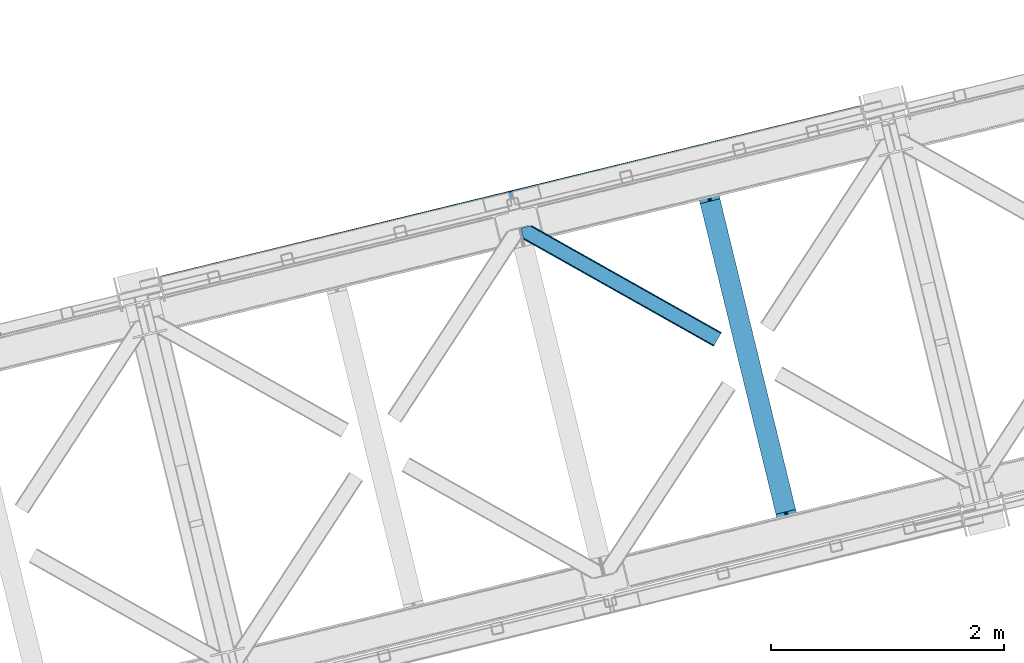
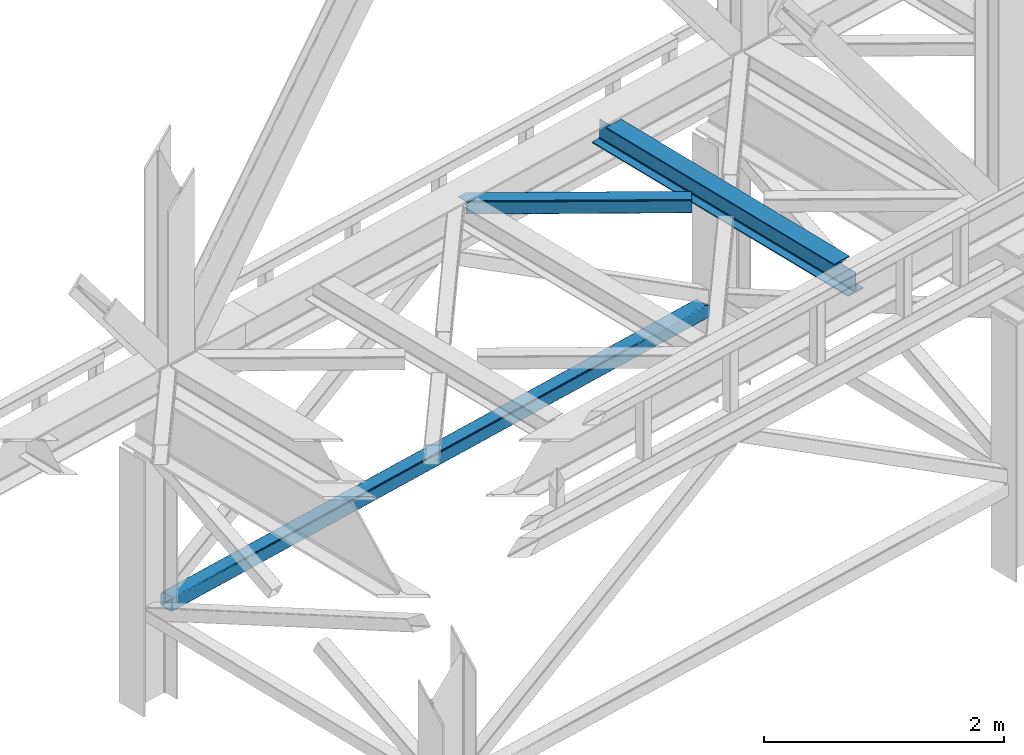
# One storey, part 48 of 93: 2 members, 1 beam.
"""IFC4 building model written with IfcOpenShell, lengths in millimetres."""

import ifcopenshell
import ifcopenshell.guid

model = None  # the IFC model being written
_history = None  # IfcOwnerHistory: only IFC2X3 demands one
_inside = {}  # id of a spatial element -> (the spatial element, [elements in it])
_under = {}  # id of a project, library or spatial element -> (it, [spatial elements below it])
_declared = {}  # id of a project -> (the project, [libraries it declares])
_typed = {}  # id of a type object -> (the type object, [elements of that type])
_made_of = {}  # id of a material, layer set ... -> (it, [elements and type objects made of it])


def new_model(schema):
    """Start an empty IFC model of exactly this schema.

    Asked for "IFC4X3", IfcOpenShell would pick the latest addendum, in which some entities
    have other attributes; the version numbers below select the first issue.
    IFC2X3 requires an IfcOwnerHistory on every rooted entity: one is made here for all.
    """
    global model, _history
    if schema == "IFC4X3":
        model = ifcopenshell.file(schema_version=(4, 3, 0, 0))
    else:
        model = ifcopenshell.file(schema=schema)
    _inside.clear()
    _under.clear()
    _declared.clear()
    _typed.clear()
    _made_of.clear()
    _history = None
    if model.schema == "IFC2X3":
        org = make("IfcOrganization", Name="unknown")
        user = make(
            "IfcPersonAndOrganization",
            ThePerson=make("IfcPerson", FamilyName="unknown"),
            TheOrganization=org,
        )
        app = make(
            "IfcApplication",
            ApplicationDeveloper=org,
            Version="unknown",
            ApplicationFullName="unknown",
            ApplicationIdentifier="unknown",
        )
        _history = make(
            "IfcOwnerHistory",
            OwningUser=user,
            OwningApplication=app,
            ChangeAction="ADDED",
            CreationDate=0,
        )
    return model


def make(cls, **values):
    """One entity of the class cls with the attributes given. An attribute that is None is left unset."""
    return model.create_entity(
        cls, **{name: value for name, value in values.items() if value is not None}
    )


def entity(cls, *values):
    """Any entity or typed value of the class cls, its attributes in the order of the schema. None: left unset."""
    e = model.create_entity(cls)
    for i, value in enumerate(values):
        if value is not None:
            e[i] = value
    return e


def rooted(cls, **values):
    """An entity with a GlobalId (a new one), such as an element, a storey or a relation."""
    return make(cls, GlobalId=ifcopenshell.guid.new(), OwnerHistory=_history, **values)


def si_unit(unit_type, name, prefix=None):
    """IfcSIUnit, for example si_unit("LENGTHUNIT", "METRE", prefix="MILLI")."""
    return make("IfcSIUnit", UnitType=unit_type, Prefix=prefix, Name=name)


def converted_unit(unit_type, name, factor, base, dimensions=None, offset=None):
    """IfcConversionBasedUnit, such as the inch: factor (a typed value) times the base unit."""
    return make(
        "IfcConversionBasedUnit"
        if offset is None
        else "IfcConversionBasedUnitWithOffset",
        ConversionOffset=offset,
        Dimensions=None
        if dimensions is None
        else entity("IfcDimensionalExponents", *dimensions),
        UnitType=unit_type,
        Name=name,
        ConversionFactor=make(
            "IfcMeasureWithUnit", ValueComponent=factor, UnitComponent=base
        ),
    )


def derived_unit(unit_type, elements):
    """IfcDerivedUnit: a product of units, each with its exponent."""
    return make(
        "IfcDerivedUnit",
        Elements=[
            make("IfcDerivedUnitElement", Unit=unit, Exponent=power)
            for unit, power in elements
        ],
        UnitType=unit_type,
    )


def assignment(units):
    """IfcUnitAssignment: the units of a project."""
    return None if units is None else make("IfcUnitAssignment", Units=units)


def point(xyz):
    """IfcCartesianPoint."""
    return None if xyz is None else make("IfcCartesianPoint", Coordinates=xyz)


def direction(xyz):
    """IfcDirection."""
    return None if xyz is None else make("IfcDirection", DirectionRatios=xyz)


def frame(location, z_axis=None, x_axis=None):
    """IfcAxis2Placement3D, a coordinate frame: its origin and axes. An axis left out is left unset."""
    return make(
        "IfcAxis2Placement3D",
        Location=point(location),
        Axis=direction(z_axis),
        RefDirection=direction(x_axis),
    )


def origin():
    """The frame at (0, 0, 0) with its axes left unset."""
    return frame((0.0, 0.0, 0.0))


def place(relative_to, where):
    """IfcLocalPlacement: puts the frame where relative to a parent placement (None: the world)."""
    return make(
        "IfcLocalPlacement", PlacementRelTo=relative_to, RelativePlacement=where
    )


def context(
    kind, dimensions, precision=None, world=None, true_north=None, identifier=None
):
    """IfcGeometricRepresentationContext, for example the 3D "Model" context."""
    return make(
        "IfcGeometricRepresentationContext",
        ContextIdentifier=identifier,
        ContextType=kind,
        CoordinateSpaceDimension=dimensions,
        Precision=precision,
        WorldCoordinateSystem=world,
        TrueNorth=true_north,
    )


def subcontext(parent, identifier, kind, view, scale=None):
    """IfcGeometricRepresentationSubContext, for example "Body" below "Model"."""
    return make(
        "IfcGeometricRepresentationSubContext",
        ContextIdentifier=identifier,
        ContextType=kind,
        ParentContext=parent,
        TargetScale=scale,
        TargetView=view,
    )


def project(units=None, contexts=None):
    """IfcProject with its units and contexts."""
    return rooted(
        "IfcProject",
        Name="project",
        RepresentationContexts=contexts,
        UnitsInContext=assignment(units),
    )


def spatial(cls, under=None, at=None, **own):
    """A site, building, storey or space (cls), placed at a placement, below another one or the project."""
    s = rooted(cls, ObjectPlacement=at, **own)
    if under is not None:
        _under.setdefault(under.id(), (under, []))[1].append(s)
    return s


def point_list(points):
    """IfcCartesianPointList2D or 3D."""
    cls = (
        "IfcCartesianPointList2D" if len(points[0]) == 2 else "IfcCartesianPointList3D"
    )
    return make(cls, CoordList=points)


def triangles(points, corners, closed=None, point_numbers=None):
    """IfcTriangulatedFaceSet: each triangle names its three corners, points numbered from 1."""
    return make(
        "IfcTriangulatedFaceSet",
        Coordinates=point_list(points),
        Closed=closed,
        CoordIndex=corners,
        PnIndex=point_numbers,
    )


def polygons(points, faces, closed=None, point_numbers=None):
    """IfcPolygonalFaceSet: a face is its outer loop, then its inner loops; points numbered from 1."""
    made = []
    for loops in faces:
        if len(loops) == 1:
            made.append(make("IfcIndexedPolygonalFace", CoordIndex=loops[0]))
        else:
            made.append(
                make(
                    "IfcIndexedPolygonalFaceWithVoids",
                    CoordIndex=loops[0],
                    InnerCoordIndices=loops[1:],
                )
            )
    return make(
        "IfcPolygonalFaceSet",
        Coordinates=point_list(points),
        Closed=closed,
        Faces=made,
        PnIndex=point_numbers,
    )


def shape(context_of_items, identifier, shape_type, items):
    """IfcShapeRepresentation: the items that make up one representation, for example the "Body"."""
    return make(
        "IfcShapeRepresentation",
        ContextOfItems=context_of_items,
        RepresentationIdentifier=identifier,
        RepresentationType=shape_type,
        Items=items,
    )


def material(Name=None, Category=None):
    """IfcMaterial."""
    return make("IfcMaterial", Name=Name, Category=Category)


def made_of(thing, what):
    """Note that an element or type object is made of a material, layer set ...; save() writes the relation."""
    if what is not None:
        _made_of.setdefault(what.id(), (what, []))[1].append(thing)
    return thing


def type_object(cls, material=None, **own):
    """A type object (cls), such as IfcWallType, which elements share."""
    return made_of(rooted(cls, **own), material)


def element(
    cls,
    number,
    at=None,
    inside=None,
    cuts=None,
    type_object=None,
    material=None,
    context=None,
    identifier="Body",
    shape_type=None,
    held_by="IfcProductDefinitionShape",
    body=None,
    shapes=None,
    **own,
):
    """One element of the class cls, such as IfcWall. Its Tag is "e" and its number.

    at: its placement. inside: the storey or other place that contains it. cuts: it is an
    opening in that element (IfcRelVoidsElement). A single representation is given by context,
    identifier, shape_type and body (its items); several are given by shapes. held_by: the class
    of the entity that holds the representations. save() writes the other relations.
    """
    e = rooted(cls, Tag="e%d" % number, ObjectPlacement=at, **own)
    if body is not None:
        shapes = [shape(context, identifier, shape_type, body)]
    if shapes is not None:
        e.Representation = make(held_by, Representations=shapes)
    if inside is not None:
        _inside.setdefault(inside.id(), (inside, []))[1].append(e)
    if cuts is not None:
        rooted(
            "IfcRelVoidsElement", RelatingBuildingElement=cuts, RelatedOpeningElement=e
        )
    if type_object is not None:
        _typed.setdefault(type_object.id(), (type_object, []))[1].append(e)
    return made_of(e, material)


def aggregate(whole, parts):
    """IfcRelAggregates: a whole, such as a stair, and the parts it consists of."""
    return rooted("IfcRelAggregates", RelatingObject=whole, RelatedObjects=parts)


def save(model, path):
    """Write the relations noted so far, then the file.

    IfcRelAggregates (storeys below a building ...), IfcRelContainedInSpatialStructure (elements
    in a storey), IfcRelDefinesByType, IfcRelAssociatesMaterial and IfcRelDeclares: one each for
    every whole, place, type object, material and project.
    """
    for whole, parts in _under.values():
        aggregate(whole, parts)
    for where, things in _inside.values():
        rooted(
            "IfcRelContainedInSpatialStructure",
            RelatedElements=things,
            RelatingStructure=where,
        )
    for kind, things in _typed.values():
        rooted("IfcRelDefinesByType", RelatedObjects=things, RelatingType=kind)
    for what, things in _made_of.values():
        rooted("IfcRelAssociatesMaterial", RelatedObjects=things, RelatingMaterial=what)
    for by, libraries in _declared.values():
        rooted("IfcRelDeclares", RelatingContext=by, RelatedDefinitions=libraries)
    model.write(path)


model = new_model("IFC4")

# Units and contexts
model_context = context("Model", 3, precision=0.01, world=origin(), true_north=direction((6.12303176911189e-17, 1.0)))
plan_context = context("Plan", 3, precision=0.01, world=origin(), true_north=direction((6.12303176911189e-17, 1.0)))
body_context = subcontext(model_context, "Body", "Model", "MODEL_VIEW")
ifc_project = project(units=[si_unit("LENGTHUNIT", "METRE", prefix="MILLI"), si_unit("AREAUNIT", "SQUARE_METRE"), si_unit("VOLUMEUNIT", "CUBIC_METRE"), converted_unit("PLANEANGLEUNIT", "DEGREE", entity("IfcRatioMeasure", 0.0174532925199433), si_unit("PLANEANGLEUNIT", "RADIAN"), dimensions=[0, 0, 0, 0, 0, 0, 0]), si_unit("MASSUNIT", "GRAM", prefix="KILO"), derived_unit("MASSDENSITYUNIT", [(si_unit("MASSUNIT", "GRAM", prefix="KILO"), 1), (si_unit("LENGTHUNIT", "METRE"), -3)]), derived_unit("MOMENTOFINERTIAUNIT", [(si_unit("LENGTHUNIT", "METRE"), 4)]), si_unit("TIMEUNIT", "SECOND"), si_unit("FREQUENCYUNIT", "HERTZ"), si_unit("THERMODYNAMICTEMPERATUREUNIT", "DEGREE_CELSIUS"), derived_unit("THERMALTRANSMITTANCEUNIT", [(si_unit("MASSUNIT", "GRAM", prefix="KILO"), 1), (si_unit("THERMODYNAMICTEMPERATUREUNIT", "KELVIN"), -1), (si_unit("TIMEUNIT", "SECOND"), -3)]), derived_unit("VOLUMETRICFLOWRATEUNIT", [(si_unit("LENGTHUNIT", "METRE"), 3), (si_unit("TIMEUNIT", "SECOND"), -1)]), derived_unit("MASSFLOWRATEUNIT", [(si_unit("MASSUNIT", "GRAM", prefix="KILO"), 1), (si_unit("TIMEUNIT", "SECOND"), -1)]), derived_unit("ROTATIONALFREQUENCYUNIT", [(si_unit("TIMEUNIT", "SECOND"), -1)]), si_unit("ELECTRICCURRENTUNIT", "AMPERE"), si_unit("ELECTRICVOLTAGEUNIT", "VOLT"), si_unit("POWERUNIT", "WATT"), si_unit("FORCEUNIT", "NEWTON", prefix="KILO"), si_unit("ILLUMINANCEUNIT", "LUX"), si_unit("LUMINOUSFLUXUNIT", "LUMEN"), si_unit("LUMINOUSINTENSITYUNIT", "CANDELA"), derived_unit("USERDEFINED", [(si_unit("MASSUNIT", "GRAM", prefix="KILO"), -1), (si_unit("LENGTHUNIT", "METRE"), -2), (si_unit("TIMEUNIT", "SECOND"), 3), (si_unit("LUMINOUSFLUXUNIT", "LUMEN"), 1)]), derived_unit("LINEARVELOCITYUNIT", [(si_unit("LENGTHUNIT", "METRE"), 1), (si_unit("TIMEUNIT", "SECOND"), -1)]), si_unit("PRESSUREUNIT", "PASCAL"), derived_unit("USERDEFINED", [(si_unit("LENGTHUNIT", "METRE"), -2), (si_unit("MASSUNIT", "GRAM", prefix="KILO"), 1), (si_unit("TIMEUNIT", "SECOND"), -2)]), derived_unit("LINEARFORCEUNIT", [(si_unit("MASSUNIT", "GRAM", prefix="KILO"), 1), (si_unit("LENGTHUNIT", "METRE"), 1), (si_unit("TIMEUNIT", "SECOND"), -2), (si_unit("LENGTHUNIT", "METRE"), -1)]), derived_unit("PLANARFORCEUNIT", [(si_unit("MASSUNIT", "GRAM", prefix="KILO"), 1), (si_unit("LENGTHUNIT", "METRE"), 1), (si_unit("TIMEUNIT", "SECOND"), -2), (si_unit("LENGTHUNIT", "METRE"), -2)])], contexts=[model_context, plan_context])

# Site, building, storey
site_placement = place(None, origin())
site = spatial("IfcSite", under=ifc_project, at=site_placement, CompositionType="ELEMENT")
building_placement = place(site_placement, origin())
building = spatial("IfcBuilding", under=site, at=building_placement, CompositionType="ELEMENT")
storey_placement = place(building_placement, frame((0.0, 0.0, 15900.0)))
storey = spatial("IfcBuildingStorey", under=building, at=storey_placement, CompositionType="ELEMENT", Elevation=15900.0)

# Beam
ifc_material = material(Name="Metal painted (White)")
beam_type = type_object("IfcBeamType", PredefinedType="BEAM")
beam_placement = place(storey_placement, frame((-38213.1659577761, 8471.84131437829, 3441.0)))
element("IfcBeam", 1, at=beam_placement, inside=storey, type_object=beam_type, material=ifc_material, ObjectType="Steel Beam", PredefinedType="BEAM", context=body_context, shape_type="Tessellation", body=[
    polygons([(900.985346189436, 41.4445662733092, 11.000000000004), (900.985346189436, 41.4445662733092, 2.16573425859679e-12), (170.021610174757, 3040.13999372697, 2.16573425859679e-12), (170.021610174765, 3040.13999372697, 11.000000000004), (834.91980623581, 25.3403919499667, 11.000000000004), (103.956070221139, 3024.03581940363, 11.000000000004), (828.971056214518, 23.8903211957407, 12.2179274798217), (98.007320199847, 3022.5857486494, 12.2179274798217), (823.927949458409, 22.6610105689183, 15.6862915010235), (92.9642134437384, 3021.35643802258, 15.6862915010235), (820.558253255242, 21.8396114687119, 20.8770650821657), (89.5945172405625, 3020.53503892237, 20.8770650821657), (819.374973305547, 21.5511744621206, 27.0000000000047), (88.4112372908679, 3020.24660191578, 27.0000000000047), (81.6103728838801, 3018.58881926485, 27.0000000000047), (81.6103728838801, 3018.58881926485, 203.000000000006), (88.4112372908766, 3020.24660191578, 203.000000000006), (4.33146851719357e-12, 2998.69542745366, 2.16573425859679e-12), (4.33146851719357e-12, 2998.69542745366, 10.9999999999997), (66.0655399536129, 3014.799601777, 11.000000000004), (72.0142899749097, 3016.24967253123, 12.2179274798217), (77.0573967310183, 3017.47898315805, 15.6862915010192), (80.4270929341986, 3018.30038225826, 20.8770650821657), (819.374973305556, 21.5511744621206, 203.000000000006), (812.574108898559, 19.8933918111876, 203.000000000006), (812.574108898559, 19.8933918111876, 27.0000000000047), (811.390828948878, 19.6049548045963, 20.8770650821657), (808.021132745698, 18.7835557043887, 15.6862915010192), (802.978025989589, 17.5542450775685, 12.2179274798217), (797.029275968292, 16.1041743233403, 11.000000000004), (730.963736014684, 0.0, 10.9999999999997), (730.963736014684, 0.0, 2.16573425859679e-12), (779.675212882762, 184.415062601692, 203.069791966819), (128.020401343508, 2857.75452019162, 203.000000000006), (128.243282132658, 2856.8401777572, 203.617301946336), (128.256196377182, 2856.7871977843, 217.000003693143), (779.530009633833, 185.010597404073, 217.000003676718), (779.530880241726, 185.007025963194, 204.00000679514), (772.964911718315, 182.385463974441, 203.006342981529), (772.742064056778, 183.299815969775, 203.617301946336), (772.72914981225, 183.352795942668, 217.000003693143), (121.455336555608, 2855.1293963229, 217.000003676718), (121.45446594771, 2855.13296776377, 204.00000679514), (121.31016635866, 2855.72494066435, 203.076120467494), (121.21953693652, 2856.09673754069, 203.000000000006), (780.713494357868, 185.298194377514, 223.122939328039), (784.082490766535, 186.122464201392, 228.313710402595), (789.125126170558, 187.353708426697, 231.782072735464), (795.073705041266, 188.80448128138, 232.999999602236), (861.13915590679, 204.909021065315, 232.999999283132), (861.137682570352, 204.915065042187, 243.999994005812), (691.116301666435, 163.469558245297, 243.999994827032), (691.117775002873, 163.463514268424, 233.000000104353), (757.183225868396, 179.568054052358, 232.999999785253), (763.132130996722, 181.017488520581, 231.782072861016), (768.175695503857, 182.244921343716, 228.313710479427), (771.546082413598, 183.063487001148, 223.12293937232), (120.271851831572, 2854.84179934945, 223.122939328039), (116.902855422893, 2854.01752952557, 228.313710402595), (111.860220018873, 2852.78628530027, 231.782072735464), (105.911641148157, 2851.33551244559, 232.999999602236), (39.8461902826462, 2835.23097266165, 232.999999283128), (39.8476636190837, 2835.22492868478, 243.999994005812), (209.869044523001, 2876.67043548167, 243.999994827032), (209.867571186563, 2876.67647945855, 233.000000104357), (143.80212032104, 2860.57193967461, 232.999999785253), (137.853215192705, 2859.12250520638, 231.782072861012), (132.809650685574, 2857.89507238325, 228.313710479427), (129.439263775834, 2857.07650672582, 223.12293937232)], [[[1, 2, 3, 4]], [[5, 1, 4, 6]], [[7, 5, 6, 8]], [[9, 7, 8, 10]], [[11, 9, 10, 12]], [[13, 11, 12, 14]], [[15, 16, 17, 14, 12, 10, 8, 6, 4, 3, 18, 19, 20, 21, 22, 23]], [[13, 24, 25, 26, 27, 28, 29, 30, 31, 32, 2, 1, 5, 7, 9, 11]], [[2, 32, 18, 3]], [[32, 31, 19, 18]], [[31, 30, 20, 19]], [[27, 26, 15, 23]], [[28, 27, 23, 22]], [[29, 28, 22, 21]], [[30, 29, 21, 20]], [[33, 24, 13, 14, 17, 34, 35, 36, 37, 38]], [[25, 39, 40, 41, 42, 43, 44, 16, 15, 26]], [[39, 25, 24, 33]], [[45, 34, 17, 16]], [[41, 40, 38, 37, 46, 47, 48, 49, 50, 51, 52, 53, 54, 55, 56, 57]], [[42, 58, 59, 60, 61, 62, 63, 64, 65, 66, 67, 68, 69, 36, 35, 43]], [[46, 37, 36, 69]], [[47, 46, 69, 68]], [[48, 47, 68, 67]], [[49, 48, 67, 66]], [[50, 49, 66, 65]], [[51, 50, 65, 64]], [[52, 51, 64, 63]], [[53, 52, 63, 62]], [[54, 53, 62, 61]], [[55, 54, 61, 60]], [[56, 55, 60, 59]], [[57, 56, 59, 58]], [[41, 57, 58, 42]]], closed=False),
])

# Members
member_type_1 = type_object("IfcMemberType", PredefinedType="BRACE")
member_1_placement = place(storey_placement, frame((-42814.5757714011, 10549.1946715413, 828.007590278974)))
element("IfcMember", 2, at=member_1_placement, inside=storey, type_object=member_type_1, ObjectType="Steel Vertical Brace", PredefinedType="BRACE", context=body_context, shape_type="Tessellation", body=[
    polygons([(31.1823923917484, 8.09507685196325, 17.8030399336157), (31.49787036771, 6.80086440699434, 24.5000000000053), (6043.46200614715, 1472.2807278312, 24.5000000000053), (6043.1465281712, 1473.57494027617, 17.8030399336157), (30.2839871258991, 11.7806820741885, 12.1256313292363), (6042.24812290534, 1477.2605454984, 12.1256313292363), (28.9394286278191, 17.2965800886775, 8.33210818105647), (6040.90356440726, 1482.77644351289, 8.33210818105647), (27.3534137403731, 23.8030254244704, 7.00000000000491), (6039.31754951982, 1489.28288884868, 7.00000000000491), (31.49787036771, 6.80086440699434, 115.500000000006), (1233.89069752359, 299.896837091836, 115.500000000006), (2436.28352467949, 592.992809776676, 115.500000000006), (3638.67635183538, 886.08878246152, 115.500000000006), (4841.06917899127, 1179.18475514636, 115.500000000006), (6043.46200614715, 1472.2807278312, 115.500000000006), (5.80223927825257, 112.214262715345, 7.00000000000491), (6017.7663750577, 1577.69412613955, 7.00000000000491), (33.155653018643, 4.33146851719357e-12, 122.500000000005), (32.9849557235693, 0.700266200652317, 127.470660132269), (30.3790881322204, 11.3905410333565, 127.459327979244), (31.1823923917571, 8.09507685196974, 122.196960066389), (4.21622439081527, 118.720708051138, 8.33210818105647), (2.87166589274391, 124.236606065627, 12.1256313292407), (1.97326062688594, 127.922211287852, 17.8030399336157), (1.65778265093302, 129.216423732821, 24.5000000000053), (1.65778265093302, 129.216423732821, 115.500000000006), (1.97326062688594, 127.922211287852, 122.196960066394), (2.75017783787762, 124.7349969661, 127.339177960748), (0.160838919820344, 135.357464800191, 127.327917686072), (0.0, 136.017288139811, 122.500000000005), (0.0, 136.017288139811, 17.5000000000047), (0.315477975952922, 134.723075694844, 10.8030399336108), (1.21388324180223, 131.037470472619, 5.12563132923793), (2.55844173989092, 125.521572458126, 1.33210818105806), (4.14445662732821, 119.015127122335, 2.16573425859679e-12), (29.0111963913148, 17.0021610174804, 6.49720277579036e-12), (30.5972112787521, 10.4957156816875, 1.33210818105806), (31.9417697768321, 4.97981766719851, 5.12563132923793), (32.8401750426901, 1.2942124449754, 10.8030399336108), (33.155653018643, 4.33146851719357e-12, 17.5000000000047), (6042.34390681963, 1476.86760290543, 127.45624675396), (6044.94930773645, 1466.17924255184, 127.467576960195), (6045.11978879809, 1465.47986342421, 122.500000000005), (6045.11978879809, 1465.47986342421, 17.5000000000047), (6044.80431082213, 1466.77407586918, 10.8030399336108), (6043.90590555628, 1470.45968109141, 5.12563132923793), (6042.56134705819, 1475.9755791059, 1.33210818105806), (6040.97533217076, 1482.48202444169, 6.49720277579036e-12), (6016.10859240677, 1584.49499054654, 2.16573425859679e-12), (6014.52257751934, 1591.00143588234, 1.33210818105806), (6013.17801902125, 1596.51733389683, 5.12563132923793), (6012.2796137554, 1600.20293911905, 10.8030399336108), (6011.96413577945, 1601.49715156402, 17.5000000000047), (6011.96413577944, 1601.49715156402, 122.500000000005), (6012.12476500034, 1600.83818849032, 127.324831620517), (6014.71364194229, 1590.21761586052, 127.336089968395), (6013.93739640643, 1593.40207471184, 122.196960066244), (6013.62191843038, 1594.69628715703, 115.500000000006), (6013.62191843038, 1594.69628715703, 24.5000000000053), (6013.93739640633, 1593.40207471206, 17.8030399336157), (6014.83580167219, 1589.71646948984, 12.1256313292407), (6016.18036017027, 1584.20057147535, 8.33210818105647), (6043.14652817119, 1473.57494027618, 122.196960066389), (4811.22909127449, 1301.60031447219, 115.500000000006), (3608.8362641186, 1008.50434178735, 115.500000000006), (2406.4434369627, 715.408369102503, 115.500000000006), (1204.05060980682, 422.312396417663, 115.500000000006), (3636.11791009549, 896.584498143203, 131.667891818953), (3634.53189520805, 903.090943478994, 133.000000000004), (4836.92472236394, 1196.18691616384, 133.000000000004), (4838.51073725137, 1189.68047082805, 131.667891818953), (2433.72508293959, 603.488525458363, 131.667891818953), (2432.13906805215, 609.994970794152, 133.000000000004), (1231.33225578369, 310.392552773519, 131.667891818953), (1229.74624089627, 316.89899810931, 133.000000000004), (3637.46246859357, 891.068600128712, 127.874368670769), (4839.85529574946, 1184.16457281355, 127.874368670771), (2435.06964143768, 597.972627443872, 127.874368670769), (1232.67681428178, 304.876654759035, 127.874368670766), (3638.36087385943, 887.382994906487, 122.196960066394), (4840.75370101531, 1180.47896759133, 122.196960066394), (2435.96804670353, 594.287022221647, 122.196960066394), (1233.57521954764, 301.191049536799, 122.1969600664), (31.5504186274805, 12.1281026343613, 127.832047239099), (6022.29615988911, 1481.61969697296, 132.66374240706), (6026.48857358031, 1479.26263699122, 131.667891818949), (6032.74254555655, 1477.67299982283, 130.0507182153), (6040.81773918208, 1476.91187433268, 127.874368670773), (6020.32641658999, 1484.6535992748, 133.000000000004), (45.981349439462, 24.8297337603205, 132.66374240706), (46.3340058948892, 28.4297455728429, 133.000000000004), (43.3438788514517, 20.80781722677, 131.667891818953), (38.5229506464551, 16.5185559690675, 130.0507182153), (4811.54456925045, 1300.30610202722, 122.1969600664), (3609.15174209455, 1007.21012934238, 122.196960066394), (2406.75891493867, 714.114156657536, 122.196960066394), (1204.36608778277, 421.018183972692, 122.196960066394), (3610.05014736041, 1003.52452412015, 127.874368670769), (4812.4429745163, 1296.62049680499, 127.874368670766), (2407.65732020452, 710.428551435313, 127.874368670769), (1205.26449304862, 417.332578750467, 127.874368670771), (3611.39470585849, 998.008626105662, 131.667891818953), (4813.78753301438, 1291.10459879051, 131.667891818955), (2409.00187870261, 704.912653420822, 131.667891818953), (1206.60905154672, 411.816680735978, 131.667891818953), (3612.98072074592, 991.502180769869, 133.000000000007), (4815.37354790182, 1284.59815345471, 133.000000000004), (2410.58789359003, 698.406208085027, 133.000000000007), (1208.19506643414, 405.310235400185, 133.000000000004), (23.157414935699, 119.958818466469, 132.66374240706), (18.9881108930707, 122.321511669539, 131.667891818949), (12.7554368909559, 123.916340444452, 130.0507182153), (4.69891109592004, 124.682016415775, 127.874368670769), (6013.19586234008, 1589.26654453752, 127.819904909002), (5998.78356944494, 1576.58091450779, 132.66374240706), (5998.45494622164, 1572.98676104987, 133.000000000004), (6001.39793038448, 1580.59719782003, 131.667891818953), (6006.1975606155, 1584.88126747126, 130.0507182153), (25.1031250026595, 116.919057810016, 133.000000000004), (47.3929578131527, 129.55740684651, 140.000000000009), (45.4472477462008, 132.597167502963, 139.663742407065), (41.2779437035726, 134.959860706036, 138.667891818956), (35.0452697014491, 136.554689480946, 137.050718215304), (26.9887439064132, 137.320365452269, 134.874368670774), (17.4179740866102, 137.227464121819, 132.222479077849), (6.70075955886753, 136.279555635628, 129.196960066396), (38.4511594356894, 2.83031863612196, 129.123003693295), (48.7046952331501, 6.8258830255562, 132.222479077851), (57.2599525703218, 11.1513925842091, 134.874368670769), (64.0790728249936, 15.5431646613821, 137.050718215304), (68.9000010299816, 19.8324259190867, 138.667891818953), (71.5374716179832, 23.854342452633, 139.663742407065), (71.8901280734191, 27.4543542651554, 140.000000000007), (6006.19826436872, 1598.53798671144, 129.117416141014), (5995.9325517923, 1594.5536438762, 132.222479077843), (5987.39261474748, 1590.23186880089, 134.874368670763), (5980.59216232308, 1585.84464720485, 137.050718215296), (5975.79253209206, 1581.56057755362, 138.667891818949), (5973.17817115253, 1577.54429424139, 139.663742407056), (5972.84954792923, 1573.95014078346, 140.000000000001), (5998.08585989271, 1472.02726181223, 140.000000000001), (6000.05560319183, 1468.99335951039, 139.663742407056), (6004.24801688302, 1466.63629952865, 138.667891818951), (6010.50198885927, 1465.04666236026, 137.050718215296), (6018.5771824848, 1464.28553687012, 134.874368670765), (6028.16327259719, 1464.38217268398, 132.222479077843), (6038.89187112938, 1465.33285614169, 129.196960066392), (4813.71576525089, 1291.3990178617, 140.000000000005), (3611.322938095, 998.303045176859, 140.000000000005), (2408.9301109391, 705.207072492014, 140.000000000005), (1206.53728378321, 412.111099807175, 140.000000000005), (1231.4040235472, 310.098133702318, 140.000000000003), (2433.79685070308, 603.19410638716, 140.000000000003), (3636.18967785898, 896.290079072004, 140.000000000003), (4838.58250501488, 1189.38605175685, 140.000000000005), (3640.01865651035, 880.582130499499, 129.196960066394), (3640.33413448631, 879.28791805453, 122.500000000005), (4842.7269616422, 1172.38389073937, 122.500000000005), (4842.41148366624, 1173.67810318434, 129.196960066392), (2437.62582935447, 587.486157814659, 129.196960066394), (2437.94130733042, 586.191945369686, 122.500000000005), (1235.23300219857, 294.390185129813, 129.196960066388), (1235.54848017453, 293.095972684846, 122.500000000005), (3639.1202512445, 884.267735721724, 134.874368670769), (4841.51307840039, 1177.36370840656, 134.874368670769), (2436.72742408862, 591.171763036882, 134.874368670769), (1234.33459693272, 298.075790352036, 134.874368670769), (3637.77569274641, 889.783633736213, 138.667891818953), (4840.1685199023, 1182.87960642106, 138.667891818953), (2435.38286559053, 596.687661051374, 138.667891818953), (1232.99003843464, 303.591688366527, 138.667891818953), (3609.73692320756, 1004.80949051265, 138.667891818951), (4812.12975036345, 1297.90546319749, 138.667891818953), (2407.34409605168, 711.713517827812, 138.667891818951), (1204.95126889578, 418.617545142968, 138.667891818953), (3608.39236470948, 1010.32538852714, 134.874368670769), (4810.78519186536, 1303.42136121198, 134.874368670769), (2405.99953755359, 717.229415842301, 134.874368670769), (1203.60671039769, 424.133443157459, 134.874368670769), (3607.49395944362, 1014.01099374937, 129.196960066394), (4809.88678659951, 1307.10696643421, 129.196960066388), (2405.10113228774, 720.915021064528, 129.196960066394), (1202.70830513184, 427.819048379682, 129.196960066392), (3607.17848146767, 1015.30520619434, 122.500000000005), (4809.57130862356, 1308.40117887918, 122.500000000005), (2404.78565431177, 722.209233509495, 122.500000000005), (1202.39282715588, 429.113260824653, 122.500000000005)], [[[1, 2, 3, 4]], [[5, 1, 4, 6]], [[7, 5, 6, 8]], [[9, 7, 8, 10]], [[2, 11, 12, 13, 14, 15, 16, 3]], [[17, 9, 10, 18]], [[19, 20, 21, 22, 11, 2, 1, 5, 7, 9, 17, 23, 24, 25, 26, 27, 28, 29, 30, 31, 32, 33, 34, 35, 36, 37, 38, 39, 40, 41]], [[42, 43, 44, 45, 46, 47, 48, 49, 50, 51, 52, 53, 54, 55, 56, 57, 58, 59, 60, 61, 62, 63, 18, 10, 8, 6, 4, 3, 16, 64]], [[23, 17, 18, 63]], [[24, 23, 63, 62]], [[25, 24, 62, 61]], [[26, 25, 61, 60]], [[27, 26, 60, 59, 65, 66, 67, 68]], [[69, 70, 71, 72]], [[73, 74, 70, 69]], [[75, 76, 74, 73]], [[77, 69, 72, 78]], [[79, 73, 69, 77]], [[80, 75, 73, 79]], [[81, 77, 78, 82]], [[83, 79, 77, 81]], [[84, 80, 79, 83]], [[15, 82, 64, 16]], [[14, 81, 82, 15]], [[13, 83, 81, 14]], [[12, 84, 83, 13]], [[11, 22, 84, 12]], [[84, 85, 80]], [[72, 86, 87]], [[78, 88, 89]], [[64, 89, 42]], [[89, 64, 82, 78]], [[78, 87, 88]], [[87, 78, 72]], [[72, 90, 86]], [[90, 72, 71]], [[76, 91, 92]], [[75, 91, 76]], [[91, 75, 93]], [[75, 94, 93]], [[80, 94, 75]], [[94, 80, 85]], [[85, 22, 21]], [[85, 84, 22]], [[95, 65, 59, 58]], [[96, 66, 65, 95]], [[97, 67, 66, 96]], [[98, 68, 67, 97]], [[28, 27, 68, 98]], [[99, 96, 95, 100]], [[101, 97, 96, 99]], [[102, 98, 97, 101]], [[103, 99, 100, 104]], [[105, 101, 99, 103]], [[106, 102, 101, 105]], [[107, 103, 104, 108]], [[109, 105, 103, 107]], [[110, 106, 105, 109]], [[106, 111, 112]], [[102, 113, 114]], [[28, 114, 29]], [[95, 115, 100]], [[108, 116, 117]], [[104, 116, 108]], [[116, 104, 118]], [[104, 119, 118]], [[100, 119, 104]], [[119, 100, 115]], [[115, 58, 57]], [[115, 95, 58]], [[114, 28, 98, 102]], [[102, 112, 113]], [[112, 102, 106]], [[106, 120, 111]], [[120, 106, 110]], [[92, 120, 110, 109, 107, 108, 117, 90, 71, 70, 74, 76]], [[121, 122, 123, 124, 125, 126, 127, 30, 29, 114, 113, 112, 111, 120, 92, 91, 93, 94, 85, 21, 20, 128, 129, 130, 131, 132, 133, 134]], [[135, 136, 137, 138, 139, 140, 141, 142, 143, 144, 145, 146, 147, 148, 43, 42, 89, 88, 87, 86, 90, 117, 116, 118, 119, 115, 57, 56]], [[141, 149, 150, 151, 152, 121, 134, 153, 154, 155, 156, 142]], [[157, 158, 159, 160]], [[161, 162, 158, 157]], [[163, 164, 162, 161]], [[165, 157, 160, 166]], [[167, 161, 157, 165]], [[168, 163, 161, 167]], [[169, 165, 166, 170]], [[171, 167, 165, 169]], [[172, 168, 167, 171]], [[155, 169, 170, 156]], [[154, 171, 169, 155]], [[153, 172, 171, 154]], [[172, 133, 132]], [[168, 131, 130]], [[163, 129, 128]], [[19, 128, 20]], [[44, 148, 160, 159]], [[156, 143, 142]], [[170, 143, 156]], [[143, 170, 144]], [[170, 145, 144]], [[166, 145, 170]], [[145, 166, 146]], [[166, 147, 146]], [[160, 147, 166]], [[147, 160, 148]], [[148, 44, 43]], [[164, 128, 19]], [[128, 164, 163]], [[163, 130, 129]], [[130, 163, 168]], [[168, 132, 131]], [[132, 168, 172]], [[172, 134, 133]], [[134, 172, 153]], [[173, 150, 149, 174]], [[175, 151, 150, 173]], [[176, 152, 151, 175]], [[177, 173, 174, 178]], [[179, 175, 173, 177]], [[180, 176, 175, 179]], [[181, 177, 178, 182]], [[183, 179, 177, 181]], [[184, 180, 179, 183]], [[185, 181, 182, 186]], [[187, 183, 181, 185]], [[188, 184, 183, 187]], [[31, 127, 184, 188]], [[174, 140, 139]], [[178, 138, 137]], [[182, 136, 135]], [[55, 135, 56]], [[186, 135, 55]], [[135, 186, 182]], [[182, 137, 136]], [[137, 182, 178]], [[178, 139, 138]], [[139, 178, 174]], [[174, 141, 140]], [[141, 174, 149]], [[152, 122, 121]], [[176, 122, 152]], [[122, 176, 123]], [[176, 124, 123]], [[180, 124, 176]], [[124, 180, 125]], [[180, 126, 125]], [[184, 126, 180]], [[126, 184, 127]], [[127, 31, 30]], [[19, 41, 45, 44, 159, 158, 162, 164]], [[38, 37, 49, 48]], [[39, 38, 48, 47]], [[40, 39, 47, 46]], [[41, 40, 46, 45]], [[32, 31, 188, 187, 185, 186, 55, 54]], [[33, 32, 54, 53]], [[34, 33, 53, 52]], [[35, 34, 52, 51]], [[36, 35, 51, 50]], [[37, 36, 50, 49]]], closed=True),
])
member_type_2 = type_object("IfcMemberType", PredefinedType="BRACE")
member_2_placement = place(storey_placement, frame((-39714.5107543945, 10078.1255401611, 3511.0000579834)))
element("IfcMember", 3, at=member_2_placement, inside=storey, type_object=member_type_2, ObjectType="Steel Horizontal Brace", PredefinedType="BRACE", context=body_context, shape_type="Tessellation", body=[
    triangles([(1656.08961181641, 0.0, 122.500662231447), (1656.74306030274, 1.16039428710974, 129.197927856447), (23.8869140625029, 919.172964477541, 122.500662231447), (23.4590332031294, 920.944949340821, 129.197927856447), (1658.60341186524, 4.46600646972729, 134.874325561526), (22.2265502929731, 925.991152954102, 134.874325561526), (1661.38928833008, 9.41337890625073, 138.667117309571), (20.3848022460952, 933.544180297853, 138.667117309571), (1664.67513427734, 15.2479064941417, 139.999594116212), (18.2128417968779, 942.452938842775, 139.999594116212), (1656.08961181641, 0.0, 17.5000946044929), (23.8869140625029, 919.172964477541, 17.5000946044929), (1716.19757080078, 106.737670898438, 139.999594116212), (69.4469238281235, 1034.10664672852, 139.999594116212), (0.0, 1017.17861022949, 139.999594116212), (1719.4857421875, 112.573361206056, 138.667117309571), (78.971923828125, 1036.42859802246, 138.667117309571), (1722.26929321289, 117.519570922852, 134.874325561526), (87.0458496093779, 1038.39708251953, 134.874325561526), (1724.13197021485, 120.826345825197, 129.197927856447), (92.4408691406279, 1039.71328125, 129.197927856447), (1724.78541870118, 121.986740112305, 122.500662231447), (94.3337768554702, 1040.17488098145, 122.500662231447), (1724.78541870118, 121.986740112305, 17.5000946044929), (94.3337768554702, 1040.17488098145, 17.5000946044929), (1656.74306030274, 1.16039428710974, 10.8028289794929), (1658.60341186524, 4.46600646972729, 5.12526855468968), (196.053149414067, 824.820584106446, 8.8831787109375), (196.076403808598, 825.06591796875, 8.50064392089917), (23.3706665039063, 921.306555175783, 10.8691040039084), (195.062512207034, 824.998480224611, 9.50058288574292), (195.732238769531, 824.878720092775, 9.08316650390771), (23.2590454101592, 921.747225952149, 9.50058288574292), (195.220642089844, 828.57035522461, 5.12526855468968), (1664.67513427734, 15.2479064941417, 0.0), (1661.38928833008, 9.41337890625073, 1.33247680664135), (193.378894042973, 836.123382568359, 1.33247680664135), (191.206933593749, 845.032141113283, 0.0), (1716.19757080078, 106.737670898438, 0.0), (157.157849121097, 984.710824584961, 0.0), (191.346459960936, 843.222949218751, 9.20757751465135), (191.290649414063, 844.068246459961, 8.85411071777344), (191.104614257813, 845.461184692384, 8.41343994140698), (18.8686157226548, 939.774032592773, 9.50058288574292), (1724.13197021485, 120.826345825197, 10.8028289794929), (92.0548461914077, 1039.61793823242, 10.8702667236357), (150.921020507813, 1006.08742675781, 9.50058288574292), (1722.26929321289, 117.519570922852, 5.12526855468968), (153.148791503911, 1001.17261047363, 5.12526855468968), (152.293029785156, 1004.67588500977, 8.50064392089917), (151.60469970703, 1005.38165588379, 9.00061340332104), (91.5851074218735, 1039.50399169922, 9.50058288574292), (1719.4857421875, 112.573361206056, 1.33247680664135), (154.985888671879, 993.619583129883, 1.33247680664135), (156.250927734378, 986.702563476563, 9.11688537597729), (155.813745117186, 987.635064697266, 9.42384338378906), (156.692761230472, 985.760760498048, 8.80760192871094), (157.129943847656, 984.82942199707, 8.50064392089917), (155.311450195317, 988.061782836914, 9.50058288574292), (72.3118652343765, 1034.80544128418, 9.50058288574292), (159.427478027348, 975.398602294923, 6.99957275390625), (188.937304687504, 854.343200683594, 6.99957275390625), (1668.10980834961, 21.3475341796875, 6.99957275390625), (1712.76289672852, 100.639205932617, 6.99957275390625), (19.9569213867217, 935.303375244141, 12.1260040283232), (1662.04041137695, 10.5656341552749, 12.1260040283232), (1664.82396240235, 15.511843872071, 8.3320495605476), (1659.52428588867, 6.0996276855476, 24.4996673583992), (1660.177734375, 7.26002197265734, 17.8035644531265), (21.6172851562515, 928.485186767579, 24.4996673583992), (21.1894042968779, 930.257171630859, 17.8035644531265), (1716.04874267578, 106.473733520508, 8.3320495605476), (1718.83461914062, 111.421105957032, 12.1260040283232), (77.0883178710938, 1035.9704864502, 12.1260040283232), (1720.69729614258, 114.726718139649, 17.8035644531265), (82.4833374023438, 1037.28552246094, 17.8035644531265), (1721.35074462891, 115.887112426759, 24.4996673583992), (84.3808959960952, 1037.74712219238, 24.4996673583992), (1659.52428588867, 6.0996276855476, 115.501089477541), (21.6172851562515, 928.485186767579, 115.501089477541), (21.1894042968779, 930.257171630859, 122.196029663086), (19.9569213867217, 935.303375244141, 127.87475280762), (15.9432128906265, 951.765161132813, 133.000021362306), (18.1151733398438, 942.855239868164, 131.667544555665), (0.0, 1017.17861022949, 133.000021362306), (1668.10980834961, 21.3475341796875, 133.000021362306), (1664.82396240235, 15.511843872071, 131.667544555665), (1662.04041137695, 10.5656341552749, 127.87475280762), (1660.177734375, 7.26002197265734, 122.196029663086), (1718.83461914062, 111.421105957032, 127.87475280762), (1720.69729614258, 114.726718139649, 122.196029663086), (1721.35074462891, 115.887112426759, 115.501089477541), (1712.76289672852, 100.639205932617, 133.000021362306), (1716.04874267578, 106.473733520508, 131.667544555665), (77.0883178710938, 1035.9704864502, 127.87475280762), (69.0143920898481, 1034.00200195313, 131.667544555665), (82.4833374023438, 1037.28552246094, 122.196029663086), (59.4893920898467, 1031.68005065918, 133.000021362306), (84.3808959960952, 1037.74712219238, 115.501089477541)], [[1, 2, 3], [4, 3, 2], [2, 5, 4], [6, 4, 5], [5, 7, 6], [8, 6, 7], [7, 9, 8], [10, 8, 9], [11, 1, 3], [3, 12, 11], [13, 10, 9], [10, 13, 14], [15, 10, 14], [13, 16, 17], [17, 14, 13], [16, 18, 19], [19, 17, 16], [18, 20, 21], [21, 19, 18], [20, 22, 23], [23, 21, 20], [22, 24, 23], [25, 23, 24], [26, 11, 12], [27, 28, 29], [26, 30, 31], [31, 27, 26], [31, 32, 27], [30, 33, 31], [29, 34, 27], [35, 36, 37], [37, 38, 35], [36, 27, 34], [34, 37, 36], [12, 30, 26], [39, 35, 38], [38, 40, 39], [41, 42, 29], [42, 43, 29], [41, 31, 33], [33, 44, 41], [45, 46, 25], [46, 45, 47], [45, 48, 49], [49, 50, 45], [45, 50, 51], [51, 47, 45], [47, 52, 46], [48, 53, 54], [54, 49, 48], [53, 39, 40], [40, 54, 53], [25, 24, 45], [51, 55, 56], [50, 57, 55], [50, 58, 57], [47, 59, 52], [60, 52, 59], [61, 40, 62], [54, 58, 49], [58, 54, 40], [49, 58, 50], [40, 61, 58], [62, 40, 38], [37, 43, 38], [43, 37, 34], [38, 43, 62], [34, 29, 43], [63, 64, 62], [61, 62, 64], [63, 62, 43], [41, 65, 66], [41, 44, 65], [43, 66, 67], [66, 43, 42], [42, 41, 66], [43, 67, 63], [68, 69, 70], [71, 70, 69], [69, 66, 71], [65, 71, 66], [72, 58, 61], [57, 72, 55], [57, 58, 72], [56, 55, 72], [73, 74, 59], [59, 72, 73], [74, 60, 59], [73, 75, 76], [76, 74, 73], [75, 77, 78], [78, 76, 75], [61, 64, 72], [79, 68, 70], [70, 80, 79], [81, 6, 82], [80, 70, 3], [4, 81, 3], [81, 4, 6], [81, 80, 3], [70, 12, 3], [71, 65, 33], [33, 30, 71], [30, 12, 71], [70, 71, 12], [83, 10, 15], [10, 84, 8], [84, 10, 83], [15, 85, 83], [84, 82, 8], [44, 33, 65], [8, 82, 6], [86, 87, 84], [84, 83, 86], [87, 88, 82], [82, 84, 87], [88, 89, 81], [81, 82, 88], [89, 79, 80], [80, 81, 89], [20, 90, 91], [92, 24, 22], [20, 91, 22], [20, 18, 90], [91, 92, 22], [90, 18, 16], [93, 13, 9], [13, 94, 16], [94, 13, 93], [94, 90, 16], [45, 73, 48], [77, 24, 92], [24, 75, 45], [75, 24, 77], [45, 75, 73], [39, 64, 35], [53, 48, 73], [73, 72, 53], [72, 64, 39], [39, 53, 72], [88, 7, 5], [9, 86, 93], [9, 87, 86], [87, 9, 7], [88, 87, 7], [79, 1, 11], [2, 89, 88], [5, 2, 88], [89, 2, 1], [79, 89, 1], [36, 66, 27], [35, 64, 63], [63, 67, 35], [67, 66, 36], [36, 35, 67], [26, 27, 66], [11, 68, 79], [69, 11, 26], [11, 69, 68], [69, 26, 66], [95, 96, 17], [19, 95, 17], [19, 21, 97], [95, 19, 97], [97, 21, 23], [96, 14, 17], [15, 98, 85], [15, 14, 98], [96, 98, 14], [97, 23, 99], [78, 25, 76], [23, 78, 99], [25, 46, 76], [23, 25, 78], [52, 76, 46], [74, 76, 52], [60, 74, 52], [93, 83, 98], [93, 86, 83], [83, 85, 98], [77, 92, 99], [99, 78, 77], [92, 91, 99], [97, 99, 91], [91, 90, 97], [95, 97, 90], [90, 94, 95], [96, 95, 94], [94, 93, 96], [98, 96, 93]]),
])

save(model, "model.ifc")
